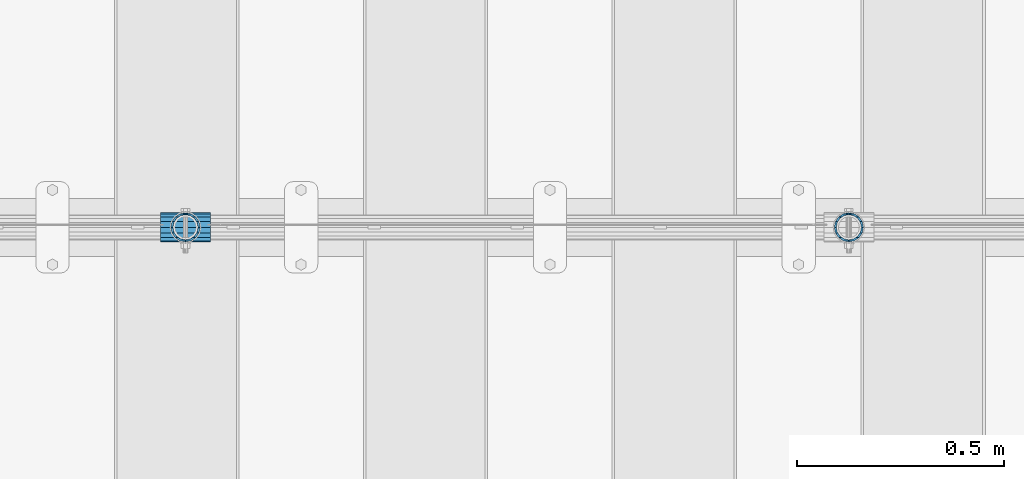
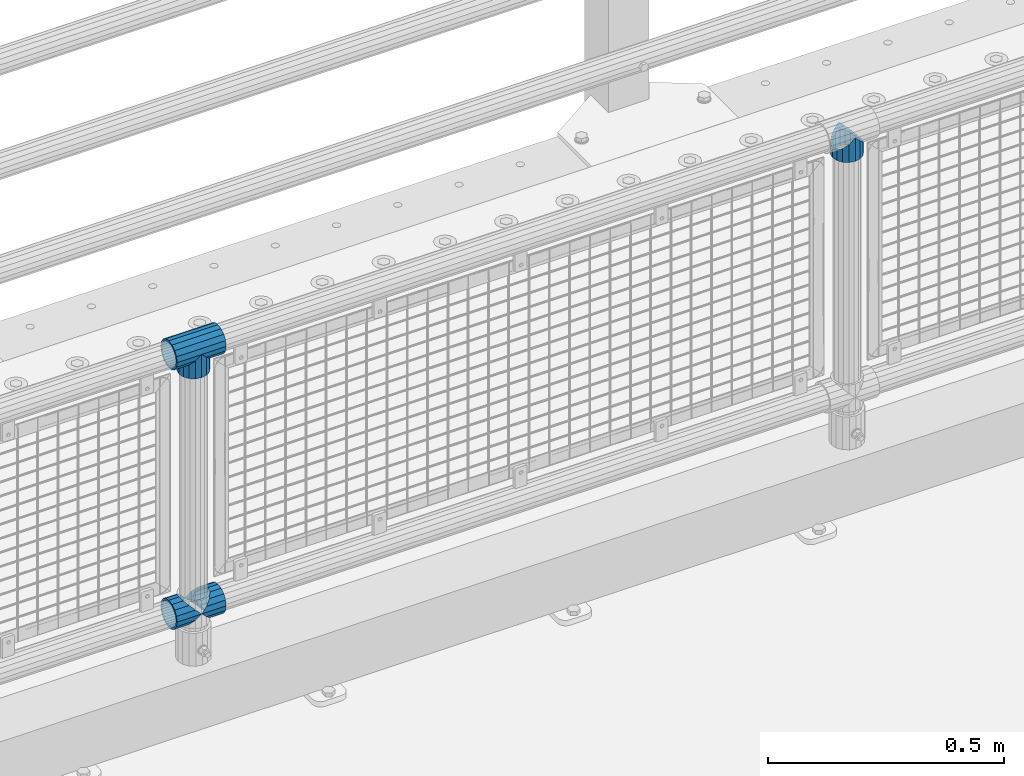
# One storey, part 149 of 257: 5 beams.
"""IFC2X3 building model written with IfcOpenShell, lengths in millimetres."""

from ifc_helpers import new_model, si_unit, frame, origin_with_axes, place, context, subcontext, project, spatial, faceted_brep, material, type_object, element, save


model = new_model("IFC2X3")

# Units and contexts
model_context = context("Model", 3, precision=1e-05, world=origin_with_axes())
body_context = subcontext(model_context, "Body", "Model", "MODEL_VIEW")
ifc_project = project(units=[si_unit("LENGTHUNIT", "METRE", prefix="MILLI"), si_unit("AREAUNIT", "SQUARE_METRE"), si_unit("VOLUMEUNIT", "CUBIC_METRE"), si_unit("MASSUNIT", "GRAM", prefix="KILO"), si_unit("TIMEUNIT", "SECOND"), si_unit("PLANEANGLEUNIT", "RADIAN"), si_unit("SOLIDANGLEUNIT", "STERADIAN"), si_unit("THERMODYNAMICTEMPERATUREUNIT", "DEGREE_CELSIUS"), si_unit("LUMINOUSINTENSITYUNIT", "LUMEN")], contexts=[model_context])

# Site, building, storey
site_placement = place(None, origin_with_axes())
site = spatial("IfcSite", under=ifc_project, at=site_placement, CompositionType="ELEMENT")
building_placement = place(site_placement, origin_with_axes())
building = spatial("IfcBuilding", under=site, at=building_placement, Name="Standard", CompositionType="ELEMENT")
storey_placement = place(building_placement, origin_with_axes())
storey = spatial("IfcBuildingStorey", under=building, at=storey_placement, Name="Undefined", CompositionType="ELEMENT", Elevation=0.0)

# Beams
ifc_material = material(Name="Misc_Undefined")
beam_type = type_object("IfcBeamType", PredefinedType="NOTDEFINED")
beam_1_placement = place(storey_placement, frame((46271.0, 10664.5, 969.849999999999), z_axis=(0.0, 1.0, 0.0), x_axis=(0.0, 0.0, -1.0)))
element("IfcBeam", 1, at=beam_1_placement, inside=storey, type_object=beam_type, material=ifc_material, context=body_context, shape_type="Brep", body=[
    faceted_brep([(0.0, 0.0, 35.1499999999996), (13.4513226476338, 13.4513226476329, 32.4743655677721), (13.4513226476338, -13.4513226476329, 32.4743655677721), (32.4743655677739, -32.4743655677717, -13.4513226476338), (32.4743655677739, -26.8123795176755, -13.4513226476338), (27.1226768591005, -21.4606908090117, -21.4606908090118), (24.8548033587067, -16.3810424080045, -24.8548033587067), (24.8548033587067, -24.8548033587072, -24.8548033587067), (13.4513226476338, -13.4513226476329, -32.4743655677721), (13.4513226476338, 13.4513226476329, -32.4743655677721), (0.0, 0.0, -35.1499999999996), (20.0882031229849, -11.6144421722805, -28.0397438117179), (16.6306603983685, 0.0, -30.3500000000004), (20.0882031229849, 11.6144421722805, -28.0397438117179), (24.8548033587067, 16.3810424080013, -24.8548033587067), (24.8548033587067, 24.8548033587072, -24.8548033587067), (32.4743655677739, 26.8123795176754, -13.4513226476338), (32.4743655677739, 32.4743655677717, -13.4513226476338), (27.1226768591005, 21.4606908090117, -21.4606908090118), (35.1500000000015, 30.35, 0.0), (35.1500000000015, 35.15, 0.0), (32.8397438117172, 28.0397438117175, -11.6144421722802), (32.8397438117172, 28.0397438117175, 11.6144421722802), (32.4743655677739, 26.8123795176755, 13.4513226476338), (32.4743655677739, 32.4743655677717, 13.4513226476338), (27.122676859115, 21.4606908090117, 21.4606908090118), (24.8548033587067, 16.3810424080013, 24.8548033587067), (24.8548033587067, 24.8548033587072, 24.8548033587067), (20.0882031229849, 11.6144421722805, 28.0397438117179), (16.6306603983758, 0.0, 30.3500000000004), (20.0882031229849, -11.6144421722805, 28.0397438117179), (24.8548033587067, -16.3810424080013, 24.8548033587067), (24.8548033587067, -24.8548033587072, 24.8548033587067), (27.122676859115, -21.4606908090117, 21.4606908090118), (32.4743655677739, -26.8123795176754, 13.4513226476338), (32.4743655677739, -32.4743655677717, 13.4513226476338), (32.8397438117172, -28.0397438117175, 11.6144421722802), (35.1500000000015, -30.35, 0.0), (35.1500000000015, -35.1499999999996, 0.0), (32.8397438117172, -28.0397438117175, -11.6144421722802), (60.1500000000015, -24.8548033587072, -24.8548033587067), (60.1500000000015, -32.4743655677717, -13.4513226476338), (60.1500000000015, -13.4513226476329, -32.4743655677721), (60.1500000000015, 0.0, -35.1499999999996), (60.1500000000015, 13.4513226476329, -32.4743655677721), (60.1500000000015, 24.8548033587072, -24.8548033587067), (60.1500000000015, 32.4743655677717, -13.4513226476338), (60.1500000000015, 35.15, 0.0), (60.1500000000015, 32.4743655677717, 13.4513226476338), (60.1500000000015, 24.8548033587072, 24.8548033587067), (60.1500000000015, 13.4513226476329, 32.4743655677721), (60.1500000000015, 0.0, 35.1499999999996), (60.1500000000015, -13.4513226476329, 32.4743655677721), (60.1500000000015, -24.8548033587072, 24.8548033587067), (60.1500000000015, -32.4743655677717, 13.4513226476338), (60.1500000000015, -35.15, 0.0), (60.1500000000015, -21.4606908090117, 21.4606908090118), (60.1500000000015, -11.6144421722805, 28.0397438117179), (60.1500000000015, 0.0, 30.3500000000004), (60.1500000000015, 11.6144421722805, 28.0397438117179), (60.1500000000015, 21.4606908090117, 21.4606908090118), (60.1500000000015, 28.0397438117175, 11.6144421722802), (60.1500000000015, 30.35, 0.0), (60.1500000000015, 28.0397438117175, -11.6144421722802), (60.1500000000015, 21.4606908090117, -21.4606908090118), (60.1500000000015, 11.6144421722805, -28.0397438117179), (60.1500000000015, 0.0, -30.3500000000004), (60.1500000000015, -11.6144421722805, -28.0397438117179), (60.1500000000015, -21.4606908090117, -21.4606908090118), (60.1500000000015, -28.0397438117175, -11.6144421722802), (60.1500000000015, -30.35, 0.0), (60.1500000000015, -28.0397438117175, 11.6144421722802)], [[[0, 1, 2]], [[3, 4, 5, 6, 7]], [[8, 9, 10]], [[7, 6, 11, 12, 13, 14, 15, 9, 8]], [[16, 17, 15, 14, 18]], [[19, 20, 17, 16, 21]], [[22, 23, 24, 20, 19]], [[25, 26, 27, 24, 23]], [[2, 1, 27, 26, 28, 29, 30, 31, 32]], [[32, 31, 33, 34, 35]], [[35, 34, 36, 37, 38]], [[38, 37, 39, 4, 3]], [[40, 41, 3, 7]], [[42, 40, 7, 8]], [[43, 42, 8, 10]], [[44, 43, 10, 9]], [[45, 44, 9, 15]], [[46, 45, 15, 17]], [[47, 46, 17, 20]], [[48, 47, 20, 24]], [[49, 48, 24, 27]], [[50, 49, 27, 1]], [[51, 50, 1, 0]], [[52, 51, 0, 2]], [[53, 52, 2, 32]], [[54, 53, 32, 35]], [[55, 54, 35, 38]], [[41, 55, 38, 3]], [[40, 42, 43, 44, 45, 46, 47, 48, 49, 50, 51, 52, 53, 54, 55, 41], [56, 57, 58, 59, 60, 61, 62, 63, 64, 65, 66, 67, 68, 69, 70, 71]], [[71, 70, 37, 36]], [[33, 56, 71, 36, 34]], [[30, 57, 56, 33, 31]], [[58, 57, 30, 29]], [[59, 58, 29, 28]], [[60, 59, 28, 26, 25]], [[61, 60, 25, 23, 22]], [[62, 61, 22, 19]], [[63, 62, 19, 21]], [[18, 64, 63, 21, 16]], [[13, 65, 64, 18, 14]], [[66, 65, 13, 12]], [[67, 66, 12, 11]], [[68, 67, 11, 6, 5]], [[69, 68, 5, 4, 39]], [[70, 69, 39, 37]]]),
])
beam_2_placement = place(storey_placement, frame((44671.0, 10664.5, 969.849999999999), z_axis=(0.0, 1.0, 0.0), x_axis=(0.0, 0.0, -1.0)))
element("IfcBeam", 2, at=beam_2_placement, inside=storey, type_object=beam_type, material=ifc_material, context=body_context, shape_type="Brep", body=[
    faceted_brep([(0.0, 0.0, 35.1499999999996), (13.4513226476338, 13.4513226476329, 32.4743655677721), (13.4513226476338, -13.4513226476329, 32.4743655677721), (32.4743655677739, -32.4743655677717, -13.4513226476338), (32.4743655677739, -26.8123795176755, -13.4513226476338), (27.1226768591005, -21.4606908090117, -21.4606908090118), (24.8548033587067, -16.3810424080045, -24.8548033587067), (24.8548033587067, -24.8548033587072, -24.8548033587067), (13.4513226476338, -13.4513226476329, -32.4743655677721), (13.4513226476338, 13.4513226476329, -32.4743655677721), (0.0, 0.0, -35.1499999999996), (20.0882031229849, -11.6144421722805, -28.0397438117179), (16.6306603983685, 0.0, -30.3500000000004), (20.0882031229849, 11.6144421722805, -28.0397438117179), (24.8548033587067, 16.3810424080013, -24.8548033587067), (24.8548033587067, 24.8548033587072, -24.8548033587067), (32.4743655677739, 26.8123795176754, -13.4513226476338), (32.4743655677739, 32.4743655677717, -13.4513226476338), (27.1226768591005, 21.4606908090117, -21.4606908090118), (35.1500000000015, 30.35, 0.0), (35.1500000000015, 35.15, 0.0), (32.8397438117172, 28.0397438117175, -11.6144421722802), (32.8397438117172, 28.0397438117175, 11.6144421722802), (32.4743655677739, 26.8123795176755, 13.4513226476338), (32.4743655677739, 32.4743655677717, 13.4513226476338), (27.122676859115, 21.4606908090117, 21.4606908090118), (24.8548033587067, 16.3810424080013, 24.8548033587067), (24.8548033587067, 24.8548033587072, 24.8548033587067), (20.0882031229849, 11.6144421722805, 28.0397438117179), (16.6306603983758, 0.0, 30.3500000000004), (20.0882031229849, -11.6144421722805, 28.0397438117179), (24.8548033587067, -16.3810424080013, 24.8548033587067), (24.8548033587067, -24.8548033587072, 24.8548033587067), (27.122676859115, -21.4606908090117, 21.4606908090118), (32.4743655677739, -26.8123795176754, 13.4513226476338), (32.4743655677739, -32.4743655677717, 13.4513226476338), (32.8397438117172, -28.0397438117175, 11.6144421722802), (35.1500000000015, -30.35, 0.0), (35.1500000000015, -35.1499999999996, 0.0), (32.8397438117172, -28.0397438117175, -11.6144421722802), (60.1500000000015, -24.8548033587072, -24.8548033587067), (60.1500000000015, -32.4743655677717, -13.4513226476338), (60.1500000000015, -13.4513226476329, -32.4743655677721), (60.1500000000015, 0.0, -35.1499999999996), (60.1500000000015, 13.4513226476329, -32.4743655677721), (60.1500000000015, 24.8548033587072, -24.8548033587067), (60.1500000000015, 32.4743655677717, -13.4513226476338), (60.1500000000015, 35.15, 0.0), (60.1500000000015, 32.4743655677717, 13.4513226476338), (60.1500000000015, 24.8548033587072, 24.8548033587067), (60.1500000000015, 13.4513226476329, 32.4743655677721), (60.1500000000015, 0.0, 35.1499999999996), (60.1500000000015, -13.4513226476329, 32.4743655677721), (60.1500000000015, -24.8548033587072, 24.8548033587067), (60.1500000000015, -32.4743655677717, 13.4513226476338), (60.1500000000015, -35.15, 0.0), (60.1500000000015, -21.4606908090117, 21.4606908090118), (60.1500000000015, -11.6144421722805, 28.0397438117179), (60.1500000000015, 0.0, 30.3500000000004), (60.1500000000015, 11.6144421722805, 28.0397438117179), (60.1500000000015, 21.4606908090117, 21.4606908090118), (60.1500000000015, 28.0397438117175, 11.6144421722802), (60.1500000000015, 30.35, 0.0), (60.1500000000015, 28.0397438117175, -11.6144421722802), (60.1500000000015, 21.4606908090117, -21.4606908090118), (60.1500000000015, 11.6144421722805, -28.0397438117179), (60.1500000000015, 0.0, -30.3500000000004), (60.1500000000015, -11.6144421722805, -28.0397438117179), (60.1500000000015, -21.4606908090117, -21.4606908090118), (60.1500000000015, -28.0397438117175, -11.6144421722802), (60.1500000000015, -30.35, 0.0), (60.1500000000015, -28.0397438117175, 11.6144421722802)], [[[0, 1, 2]], [[3, 4, 5, 6, 7]], [[8, 9, 10]], [[7, 6, 11, 12, 13, 14, 15, 9, 8]], [[16, 17, 15, 14, 18]], [[19, 20, 17, 16, 21]], [[22, 23, 24, 20, 19]], [[25, 26, 27, 24, 23]], [[2, 1, 27, 26, 28, 29, 30, 31, 32]], [[32, 31, 33, 34, 35]], [[35, 34, 36, 37, 38]], [[38, 37, 39, 4, 3]], [[40, 41, 3, 7]], [[42, 40, 7, 8]], [[43, 42, 8, 10]], [[44, 43, 10, 9]], [[45, 44, 9, 15]], [[46, 45, 15, 17]], [[47, 46, 17, 20]], [[48, 47, 20, 24]], [[49, 48, 24, 27]], [[50, 49, 27, 1]], [[51, 50, 1, 0]], [[52, 51, 0, 2]], [[53, 52, 2, 32]], [[54, 53, 32, 35]], [[55, 54, 35, 38]], [[41, 55, 38, 3]], [[40, 42, 43, 44, 45, 46, 47, 48, 49, 50, 51, 52, 53, 54, 55, 41], [56, 57, 58, 59, 60, 61, 62, 63, 64, 65, 66, 67, 68, 69, 70, 71]], [[71, 70, 37, 36]], [[33, 56, 71, 36, 34]], [[30, 57, 56, 33, 31]], [[58, 57, 30, 29]], [[59, 58, 29, 28]], [[60, 59, 28, 26, 25]], [[61, 60, 25, 23, 22]], [[62, 61, 22, 19]], [[63, 62, 19, 21]], [[18, 64, 63, 21, 16]], [[13, 65, 64, 18, 14]], [[66, 65, 13, 12]], [[67, 66, 12, 11]], [[68, 67, 11, 6, 5]], [[69, 68, 5, 4, 39]], [[70, 69, 39, 37]]]),
])
beam_3_placement = place(storey_placement, frame((44610.85, 10664.5, 969.849999999999), z_axis=(0.0, 0.0, 1.0), x_axis=(1.0, 0.0, 0.0)))
element("IfcBeam", 3, at=beam_3_placement, inside=storey, type_object=beam_type, material=ifc_material, context=body_context, shape_type="Brep", body=[
    faceted_brep([(88.1897438117157, -11.6144421722802, -28.0397438117176), (88.1897438117157, -11.6144421722802, -32.8397438117175), (86.962379517674, -13.4513226476338, -32.4743655677718), (81.6106908090151, -21.4606908090118, -27.122676859108), (81.6106908090151, -21.4606908090118, -21.4606908090117), (76.5310424080017, -24.8548033587067, -24.8548033587072), (71.7644421722798, -28.0397438117179, -20.0882031229829), (71.7644421722798, -28.0397438117179, -11.6144421722805), (60.1500000000015, -30.3500000000004, -16.6306603983671), (60.1500000000015, -30.35, 0.0), (48.5355578277231, -28.0397438117179, -20.0882031229829), (48.5355578277231, -28.0397438117179, -11.6144421722805), (43.7689575920012, -24.8548033587067, -24.8548033587072), (38.6893091909878, -21.4606908090118, -27.122676859108), (38.6893091909878, -21.4606908090118, -21.4606908090117), (33.3376204823144, -13.4513226476338, -32.4743655677718), (32.1102561882872, -11.6144421722802, -32.8397438117175), (32.1102561882872, -11.6144421722802, -28.0397438117176), (29.8000000000029, 0.0, -35.15), (29.8000000000029, 0.0, -30.35), (32.1102561882872, 11.6144421722802, -32.8397438117178), (32.1102561882872, 11.6144421722802, -28.0397438117176), (33.3376204823289, 13.4513226476338, -32.4743655677718), (38.6893091909878, 21.4606908090118, -27.1226768591091), (38.6893091909878, 21.4606908090118, -21.4606908090117), (43.7689575920012, 24.8548033587067, -24.8548033587072), (48.5355578277231, 28.0397438117179, -20.0882031229829), (48.5355578277231, 28.0397438117179, -11.6144421722805), (60.1500000000015, 30.3500000000004, -16.6306603983671), (60.1500000000015, 30.35, 0.0), (71.7644421722798, 28.0397438117179, -20.0882031229829), (71.7644421722798, 28.0397438117179, -11.6144421722805), (76.5310424080017, 24.8548033587067, -24.8548033587072), (81.6106908090151, 21.4606908090118, -27.1226768591091), (81.6106908090151, 21.4606908090118, -21.4606908090117), (86.9623795176813, 13.4513226476338, -32.4743655677718), (88.1897438117157, 11.6144421722802, -32.8397438117178), (88.1897438117157, 11.6144421722802, -28.0397438117176), (90.5, 0.0, -35.15), (90.5, 0.0, -30.35), (0.0, -21.4606908090118, -21.4606908090136), (0.0, -28.0397438117179, -11.6144421722784), (0.0, -11.6144421722802, -28.0397438117143), (0.0, 0.0, -30.3499999999985), (0.0, 11.6144421722802, -28.0397438117143), (0.0, 21.4606908090118, -21.4606908090136), (0.0, 28.0397438117179, -11.6144421722784), (0.0, 30.3500000000004, 0.0), (0.0, 32.4743655677721, -13.4513226476338), (0.0, 35.1499999999996, 0.0), (120.300000000003, 35.1499999999996, 0.0), (120.300000000003, 32.4743655677721, -13.4513226476329), (0.0, 32.4743655677721, 13.4513226476338), (120.300000000003, 32.4743655677721, 13.4513226476329), (0.0, 24.8548033587067, 24.8548033587067), (120.300000000003, 24.8548033587067, 24.8548033587072), (0.0, 13.4513226476338, 32.4743655677739), (120.300000000003, 13.4513226476338, 32.4743655677718), (0.0, 0.0, 35.1499999999996), (120.300000000003, 0.0, 35.15), (0.0, -13.4513226476338, 32.4743655677739), (120.300000000003, -13.4513226476338, 32.4743655677718), (0.0, -24.8548033587067, 24.8548033587067), (120.300000000003, -24.8548033587067, 24.8548033587072), (0.0, -32.4743655677721, 13.4513226476338), (120.300000000003, -32.4743655677721, 13.4513226476329), (0.0, -35.1499999999996, 0.0), (120.300000000003, -35.1499999999996, 0.0), (0.0, -32.4743655677721, -13.4513226476338), (120.300000000003, -32.4743655677721, -13.4513226476329), (0.0, 24.8548033587067, -24.8548033587067), (0.0, 13.4513226476338, -32.4743655677739), (0.0, 0.0, -35.1499999999996), (0.0, -13.4513226476338, -32.4743655677739), (0.0, -24.8548033587067, -24.8548033587067), (0.0, 28.0397438117179, 11.6144421722784), (0.0, 21.4606908090118, 21.4606908090136), (0.0, 11.6144421722802, 28.0397438117143), (0.0, 0.0, 30.3499999999985), (0.0, -11.6144421722802, 28.0397438117143), (0.0, -21.4606908090118, 21.4606908090136), (0.0, -28.0397438117179, 11.6144421722784), (0.0, -30.3500000000004, 0.0), (120.300000000003, -30.3500000000004, 0.0), (120.300000000003, -28.0397438117179, -11.6144421722805), (120.300000000003, -21.4606908090118, -21.4606908090117), (120.300000000003, -11.6144421722802, -28.0397438117176), (120.300000000003, 0.0, -30.35), (120.300000000003, 21.4606908090118, -21.4606908090117), (120.300000000003, 28.0397438117179, -11.6144421722805), (120.300000000003, 11.6144421722802, -28.0397438117176), (120.300000000003, 30.3500000000004, 0.0), (120.300000000003, 28.0397438117179, 11.6144421722805), (120.300000000003, 21.4606908090118, 21.4606908090117), (120.300000000003, 11.6144421722802, 28.0397438117176), (120.300000000003, 0.0, 30.35), (120.300000000003, -11.6144421722802, 28.0397438117176), (120.300000000003, -21.4606908090118, 21.4606908090117), (120.300000000003, -28.0397438117179, 11.6144421722805), (120.300000000003, -24.8548033587067, -24.8548033587072), (120.300000000003, -13.4513226476338, -32.4743655677718), (120.300000000003, 0.0, -35.15), (120.300000000003, 13.4513226476338, -32.4743655677718), (120.300000000003, 24.8548033587067, -24.8548033587072)], [[[0, 1, 2, 3, 4]], [[4, 3, 5, 6, 7]], [[7, 6, 8, 9]], [[9, 8, 10, 11]], [[11, 10, 12, 13, 14]], [[14, 13, 15, 16, 17]], [[17, 16, 18, 19]], [[19, 18, 20, 21]], [[21, 20, 22, 23, 24]], [[24, 23, 25, 26, 27]], [[27, 26, 28, 29]], [[29, 28, 30, 31]], [[31, 30, 32, 33, 34]], [[34, 33, 35, 36, 37]], [[37, 36, 38, 39]], [[39, 38, 1, 0]], [[40, 41, 11, 14]], [[42, 40, 14, 17]], [[43, 42, 17, 19]], [[44, 43, 19, 21]], [[45, 44, 21, 24]], [[46, 45, 24, 27]], [[47, 46, 27, 29]], [[48, 49, 50, 51]], [[49, 52, 53, 50]], [[52, 54, 55, 53]], [[54, 56, 57, 55]], [[56, 58, 59, 57]], [[58, 60, 61, 59]], [[60, 62, 63, 61]], [[62, 64, 65, 63]], [[64, 66, 67, 65]], [[66, 68, 69, 67]], [[64, 62, 60, 58, 56, 54, 52, 49, 48, 70, 71, 72, 73, 74, 68, 66], [41, 40, 42, 43, 44, 45, 46, 47, 75, 76, 77, 78, 79, 80, 81, 82]], [[41, 82, 9, 11]], [[83, 84, 7, 9]], [[84, 85, 4, 7]], [[85, 86, 0, 4]], [[86, 87, 39, 0]], [[88, 89, 31, 34]], [[90, 88, 34, 37]], [[87, 90, 37, 39]], [[89, 91, 29, 31]], [[75, 47, 29, 91, 92]], [[76, 75, 92, 93]], [[77, 76, 93, 94]], [[78, 77, 94, 95]], [[79, 78, 95, 96]], [[80, 79, 96, 97]], [[81, 80, 97, 98]], [[9, 82, 81, 98, 83]], [[99, 100, 101, 102, 103, 51, 50, 53, 55, 57, 59, 61, 63, 65, 67, 69], [97, 96, 95, 94, 93, 92, 91, 89, 88, 90, 87, 86, 85, 84, 83, 98]], [[35, 102, 101, 38, 36]], [[32, 103, 102, 35, 33]], [[28, 26, 25, 70, 48, 51, 103, 32, 30]], [[22, 71, 70, 25, 23]], [[18, 72, 71, 22, 20]], [[73, 72, 18, 16, 15]], [[74, 73, 15, 13, 12]], [[99, 69, 68, 74, 12, 10, 8, 6, 5]], [[100, 99, 5, 3, 2]], [[101, 100, 2, 1, 38]]]),
])
beam_4_placement = place(storey_placement, frame((44610.85, 10664.5, 298.17), z_axis=(0.0, 1.0, 0.0), x_axis=(1.0, 0.0, 0.0)))
element("IfcBeam", 4, at=beam_4_placement, inside=storey, type_object=beam_type, material=ifc_material, context=body_context, shape_type="Brep", body=[
    faceted_brep([(60.1500000000015, 0.0, -35.1499999999996), (46.6986773523677, 13.4513226476329, -32.4743655677721), (46.6986773523677, -13.4513226476329, -32.4743655677721), (33.0273231408937, 21.4606908090117, 21.4606908090118), (27.6756344322275, 26.8123795176764, 13.4513226476338), (27.6756344322275, 32.4743655677717, 13.4513226476338), (35.2951966412948, 24.8548033587072, 24.8548033587067), (35.2951966412948, 16.3810424080013, 24.8548033587067), (27.3102561882843, 28.0397438117175, 11.6144421722802), (25.0, 30.35, 0.0), (25.0, 35.15, 0.0), (27.6756344322275, 26.8123795176754, -13.4513226476338), (27.6756344322275, 32.4743655677717, -13.4513226476338), (27.3102561882843, 28.0397438117175, -11.6144421722802), (35.2951966412948, 16.3810424080013, -24.8548033587067), (35.2951966412948, 24.8548033587072, -24.8548033587067), (33.0273231408864, 21.4606908090117, -21.4606908090118), (40.0617968770239, 11.6144421722805, -28.0397438117179), (43.5193396016475, 0.0, -30.3500000000004), (40.0617968770239, -11.6144421722805, -28.0397438117179), (35.2951966412948, -16.3810424080078, -24.8548033587067), (35.2951966412948, -24.8548033587072, -24.8548033587067), (33.0273231408864, -21.4606908090117, -21.4606908090118), (27.6756344322275, -26.8123795176764, -13.4513226476338), (27.6756344322275, -32.4743655677717, -13.4513226476338), (27.3102561882843, -28.0397438117175, -11.6144421722802), (25.0, -30.35, 0.0), (25.0, -35.15, 0.0), (27.3102561882843, -28.0397438117175, 11.6144421722802), (27.6756344322275, -26.8123795176754, 13.4513226476338), (27.6756344322275, -32.4743655677717, 13.4513226476338), (33.0273231408937, -21.4606908090117, 21.4606908090118), (35.2951966412948, -16.3810424080045, 24.8548033587067), (35.2951966412948, -24.8548033587072, 24.8548033587067), (60.1500000000015, 0.0, 35.1499999999996), (46.6986773523677, -13.4513226476329, 32.4743655677721), (46.6986773523677, 13.4513226476329, 32.4743655677721), (40.0617968770166, -11.6144421722805, 28.0397438117179), (43.519339601633, 0.0, 30.3500000000004), (40.0617968770166, 11.6144421722805, 28.0397438117179), (0.0, -32.4743655677721, -13.4513226476338), (0.0, -24.8548033587067, -24.8548033587067), (0.0, -13.4513226476338, -32.4743655677739), (0.0, 0.0, -35.1499999999996), (0.0, 13.4513226476338, -32.4743655677739), (0.0, 24.8548033587067, -24.8548033587067), (0.0, 32.4743655677721, -13.4513226476338), (0.0, 35.1499999999996, 0.0), (0.0, 32.4743655677721, 13.4513226476338), (0.0, 24.8548033587067, 24.8548033587067), (0.0, 13.4513226476338, 32.4743655677739), (0.0, 0.0, 35.1499999999996), (0.0, -32.4743655677721, 13.4513226476338), (0.0, -35.1499999999996, 0.0), (0.0, -24.8548033587067, 24.8548033587067), (0.0, -13.4513226476338, 32.4743655677739), (0.0, -28.0397438117179, -11.6144421722784), (0.0, -21.4606908090118, -21.4606908090136), (0.0, -11.6144421722802, -28.0397438117143), (0.0, 0.0, -30.3499999999985), (0.0, 11.6144421722802, -28.0397438117143), (0.0, 21.4606908090118, -21.4606908090136), (0.0, 28.0397438117179, -11.6144421722784), (0.0, 30.3500000000004, 0.0), (0.0, 28.0397438117179, 11.6144421722784), (0.0, 21.4606908090118, 21.4606908090136), (0.0, 11.6144421722802, 28.0397438117143), (0.0, 0.0, 30.3499999999985), (0.0, -11.6144421722802, 28.0397438117143), (0.0, -21.4606908090118, 21.4606908090136), (0.0, -28.0397438117179, 11.6144421722784), (0.0, -30.3500000000004, 0.0)], [[[0, 1, 2]], [[3, 4, 5, 6, 7]], [[8, 9, 10, 5, 4]], [[11, 12, 10, 9, 13]], [[14, 15, 12, 11, 16]], [[2, 1, 15, 14, 17, 18, 19, 20, 21]], [[21, 20, 22, 23, 24]], [[24, 23, 25, 26, 27]], [[27, 26, 28, 29, 30]], [[30, 29, 31, 32, 33]], [[34, 35, 36]], [[33, 32, 37, 38, 39, 7, 6, 36, 35]], [[40, 41, 21, 24]], [[41, 42, 2, 21]], [[42, 43, 0, 2]], [[43, 44, 1, 0]], [[44, 45, 15, 1]], [[45, 46, 12, 15]], [[46, 47, 10, 12]], [[47, 48, 5, 10]], [[48, 49, 6, 5]], [[49, 50, 36, 6]], [[50, 51, 34, 36]], [[52, 53, 27, 30]], [[54, 52, 30, 33]], [[55, 54, 33, 35]], [[51, 55, 35, 34]], [[53, 40, 24, 27]], [[52, 54, 55, 51, 50, 49, 48, 47, 46, 45, 44, 43, 42, 41, 40, 53], [56, 57, 58, 59, 60, 61, 62, 63, 64, 65, 66, 67, 68, 69, 70, 71]], [[68, 67, 38, 37]], [[31, 69, 68, 37, 32]], [[28, 70, 69, 31, 29]], [[71, 70, 28, 26]], [[56, 71, 26, 25]], [[57, 56, 25, 23, 22]], [[58, 57, 22, 20, 19]], [[59, 58, 19, 18]], [[60, 59, 18, 17]], [[16, 61, 60, 17, 14]], [[13, 62, 61, 16, 11]], [[63, 62, 13, 9]], [[64, 63, 9, 8]], [[65, 64, 8, 4, 3]], [[66, 65, 3, 7, 39]], [[67, 66, 39, 38]]]),
])
beam_5_placement = place(storey_placement, frame((44671.0, 10664.5, 298.17), z_axis=(0.0, 1.0, 0.0), x_axis=(1.0, 0.0, 0.0)))
element("IfcBeam", 5, at=beam_5_placement, inside=storey, type_object=beam_type, material=ifc_material, context=body_context, shape_type="Brep", body=[
    faceted_brep([(0.0, 0.0, 35.1499999999996), (13.4513226476338, 13.4513226476329, 32.4743655677721), (13.4513226476338, -13.4513226476329, 32.4743655677721), (32.4743655677739, -32.4743655677717, -13.4513226476338), (32.4743655677739, -26.8123795176755, -13.4513226476338), (27.1226768591005, -21.4606908090117, -21.4606908090118), (24.8548033587067, -16.3810424080045, -24.8548033587067), (24.8548033587067, -24.8548033587072, -24.8548033587067), (13.4513226476338, -13.4513226476329, -32.4743655677721), (13.4513226476338, 13.4513226476329, -32.4743655677721), (0.0, 0.0, -35.1499999999996), (20.0882031229849, -11.6144421722805, -28.0397438117179), (16.6306603983685, 0.0, -30.3500000000004), (20.0882031229849, 11.6144421722805, -28.0397438117179), (24.8548033587067, 16.3810424080013, -24.8548033587067), (24.8548033587067, 24.8548033587072, -24.8548033587067), (32.4743655677739, 26.8123795176754, -13.4513226476338), (32.4743655677739, 32.4743655677717, -13.4513226476338), (27.1226768591005, 21.4606908090117, -21.4606908090118), (35.1500000000015, 30.35, 0.0), (35.1500000000015, 35.15, 0.0), (32.8397438117172, 28.0397438117175, -11.6144421722802), (32.8397438117172, 28.0397438117175, 11.6144421722802), (32.4743655677739, 26.8123795176755, 13.4513226476338), (32.4743655677739, 32.4743655677717, 13.4513226476338), (27.122676859115, 21.4606908090117, 21.4606908090118), (24.8548033587067, 16.3810424080013, 24.8548033587067), (24.8548033587067, 24.8548033587072, 24.8548033587067), (20.0882031229849, 11.6144421722805, 28.0397438117179), (16.6306603983758, 0.0, 30.3500000000004), (20.0882031229849, -11.6144421722805, 28.0397438117179), (24.8548033587067, -16.3810424080013, 24.8548033587067), (24.8548033587067, -24.8548033587072, 24.8548033587067), (27.122676859115, -21.4606908090117, 21.4606908090118), (32.4743655677739, -26.8123795176754, 13.4513226476338), (32.4743655677739, -32.4743655677717, 13.4513226476338), (32.8397438117172, -28.0397438117175, 11.6144421722802), (35.1500000000015, -30.35, 0.0), (35.1500000000015, -35.1499999999996, 0.0), (32.8397438117172, -28.0397438117175, -11.6144421722802), (60.1500000000015, -24.8548033587072, -24.8548033587067), (60.1500000000015, -32.4743655677717, -13.4513226476338), (60.1500000000015, -13.4513226476329, -32.4743655677721), (60.1500000000015, 0.0, -35.1499999999996), (60.1500000000015, 13.4513226476329, -32.4743655677721), (60.1500000000015, 24.8548033587072, -24.8548033587067), (60.1500000000015, 32.4743655677717, -13.4513226476338), (60.1500000000015, 35.15, 0.0), (60.1500000000015, 32.4743655677717, 13.4513226476338), (60.1500000000015, 24.8548033587072, 24.8548033587067), (60.1500000000015, 13.4513226476329, 32.4743655677721), (60.1500000000015, 0.0, 35.1499999999996), (60.1500000000015, -13.4513226476329, 32.4743655677721), (60.1500000000015, -24.8548033587072, 24.8548033587067), (60.1500000000015, -32.4743655677717, 13.4513226476338), (60.1500000000015, -35.15, 0.0), (60.1500000000015, -21.4606908090117, 21.4606908090118), (60.1500000000015, -11.6144421722805, 28.0397438117179), (60.1500000000015, 0.0, 30.3500000000004), (60.1500000000015, 11.6144421722805, 28.0397438117179), (60.1500000000015, 21.4606908090117, 21.4606908090118), (60.1500000000015, 28.0397438117175, 11.6144421722802), (60.1500000000015, 30.35, 0.0), (60.1500000000015, 28.0397438117175, -11.6144421722802), (60.1500000000015, 21.4606908090117, -21.4606908090118), (60.1500000000015, 11.6144421722805, -28.0397438117179), (60.1500000000015, 0.0, -30.3500000000004), (60.1500000000015, -11.6144421722805, -28.0397438117179), (60.1500000000015, -21.4606908090117, -21.4606908090118), (60.1500000000015, -28.0397438117175, -11.6144421722802), (60.1500000000015, -30.35, 0.0), (60.1500000000015, -28.0397438117175, 11.6144421722802)], [[[0, 1, 2]], [[3, 4, 5, 6, 7]], [[8, 9, 10]], [[7, 6, 11, 12, 13, 14, 15, 9, 8]], [[16, 17, 15, 14, 18]], [[19, 20, 17, 16, 21]], [[22, 23, 24, 20, 19]], [[25, 26, 27, 24, 23]], [[2, 1, 27, 26, 28, 29, 30, 31, 32]], [[32, 31, 33, 34, 35]], [[35, 34, 36, 37, 38]], [[38, 37, 39, 4, 3]], [[40, 41, 3, 7]], [[42, 40, 7, 8]], [[43, 42, 8, 10]], [[44, 43, 10, 9]], [[45, 44, 9, 15]], [[46, 45, 15, 17]], [[47, 46, 17, 20]], [[48, 47, 20, 24]], [[49, 48, 24, 27]], [[50, 49, 27, 1]], [[51, 50, 1, 0]], [[52, 51, 0, 2]], [[53, 52, 2, 32]], [[54, 53, 32, 35]], [[55, 54, 35, 38]], [[41, 55, 38, 3]], [[40, 42, 43, 44, 45, 46, 47, 48, 49, 50, 51, 52, 53, 54, 55, 41], [56, 57, 58, 59, 60, 61, 62, 63, 64, 65, 66, 67, 68, 69, 70, 71]], [[71, 70, 37, 36]], [[33, 56, 71, 36, 34]], [[30, 57, 56, 33, 31]], [[58, 57, 30, 29]], [[59, 58, 29, 28]], [[60, 59, 28, 26, 25]], [[61, 60, 25, 23, 22]], [[62, 61, 22, 19]], [[63, 62, 19, 21]], [[18, 64, 63, 21, 16]], [[13, 65, 64, 18, 14]], [[66, 65, 13, 12]], [[67, 66, 12, 11]], [[68, 67, 11, 6, 5]], [[69, 68, 5, 4, 39]], [[70, 69, 39, 37]]]),
])

save(model, "model.ifc")
